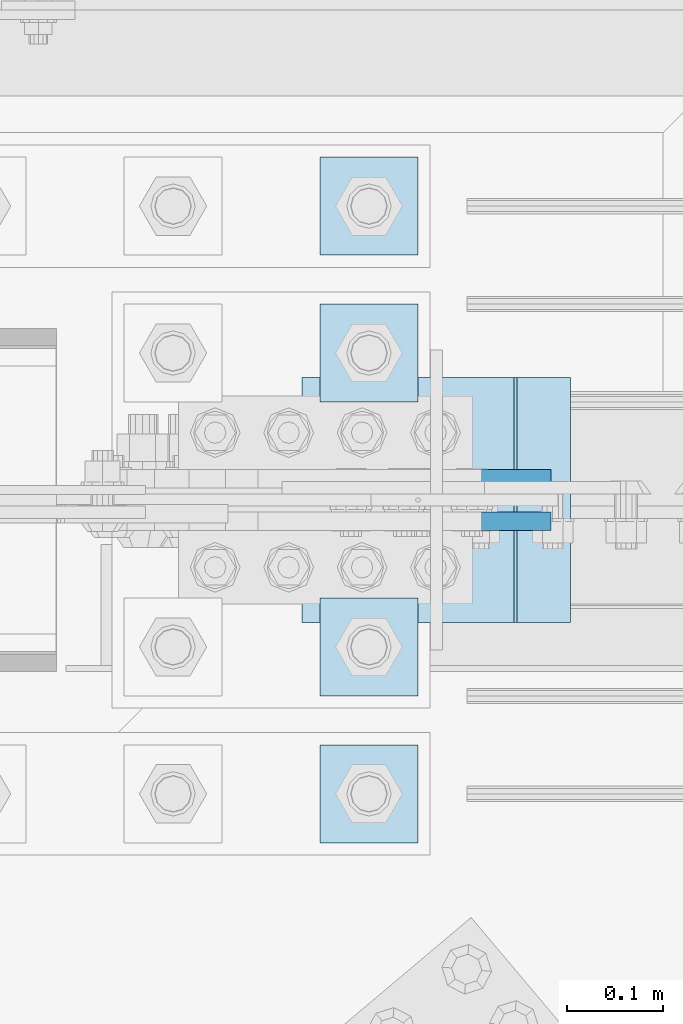
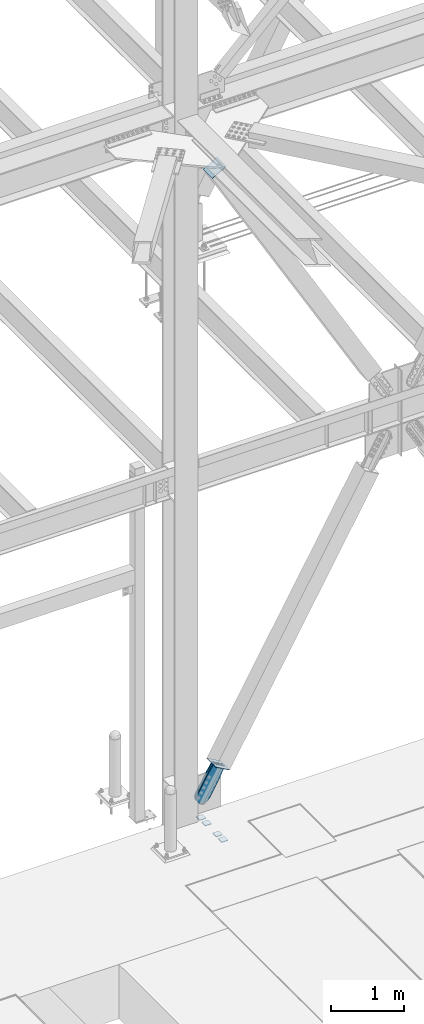
# One storey, part 3465 of 3843: 8 plates, 5 elements without a shape of their own.
"""IFC2X3 building model written with IfcOpenShell, lengths in millimetres."""

from ifc_helpers import new_model, si_unit, frame, origin_with_axes, place, context, subcontext, project, spatial, faceted_brep, material, type_object, element, aggregate, save


model = new_model("IFC2X3")

# Units and contexts
model_context = context("Model", 3, precision=1e-05, world=origin_with_axes())
body_context = subcontext(model_context, "Body", "Model", "MODEL_VIEW")
ifc_project = project(units=[si_unit("LENGTHUNIT", "METRE", prefix="MILLI"), si_unit("AREAUNIT", "SQUARE_METRE"), si_unit("VOLUMEUNIT", "CUBIC_METRE"), si_unit("MASSUNIT", "GRAM", prefix="KILO"), si_unit("TIMEUNIT", "SECOND"), si_unit("PLANEANGLEUNIT", "RADIAN"), si_unit("SOLIDANGLEUNIT", "STERADIAN"), si_unit("THERMODYNAMICTEMPERATUREUNIT", "DEGREE_CELSIUS"), si_unit("LUMINOUSINTENSITYUNIT", "LUMEN")], contexts=[model_context])

# Site, building, storey
site_placement = place(None, origin_with_axes())
site = spatial("IfcSite", under=ifc_project, at=site_placement, CompositionType="ELEMENT")
building_placement = place(site_placement, origin_with_axes())
building = spatial("IfcBuilding", under=site, at=building_placement, Name="Undefined", CompositionType="ELEMENT")
storey_placement = place(building_placement, origin_with_axes())
storey = spatial("IfcBuildingStorey", under=building, at=storey_placement, Name="Undefined", CompositionType="ELEMENT", Elevation=0.0)

# Assembly, plates
assembly_1_placement = place(storey_placement, origin_with_axes())
assembly_1 = element("IfcElementAssembly", 1, at=assembly_1_placement, inside=storey, Name="TEMPLATE", AssemblyPlace="NOTDEFINED", PredefinedType="RIGID_FRAME")
ifc_material_1 = material(Name="STEEL/A572-50")
plate_type_1 = type_object("IfcPlateType", PredefinedType="NOTDEFINED")
plate_1_placement = place(assembly_1_placement, frame((49555.4, 91960.7, 30143.45), z_axis=(-1.0, 0.0, 0.0), x_axis=(0.0, -1.0, 0.0)))
plate_1 = element("IfcPlate", 2, at=plate_1_placement, type_object=plate_type_1, material=ifc_material_1, Name="Washer Plate", context=body_context, shape_type="Brep", body=[
    faceted_brep([(0.0, -6.3499999046162, 0.0), (-1.67347025126219e-10, -6.35000000000582, 101.600000000151), (-1.67347025126219e-10, 6.35000000000582, 101.600000000151), (7.27595761418343e-12, 6.3499999046162, 0.0), (101.599998474121, -6.34999999999854, 101.599998474121), (101.599998474121, 6.34999999999854, 101.599998474121), (101.6, -6.34999999999854, 0.0), (101.6, 6.34999999999854, 0.0)], [[[0, 1, 2, 3]], [[1, 4, 5, 2]], [[4, 6, 7, 5]], [[6, 0, 3, 7]], [[5, 7, 3, 2]], [[6, 4, 1, 0]]]),
])
plate_2_placement = place(assembly_1_placement, frame((49555.4, 92113.1, 30143.45), z_axis=(-1.0, 0.0, 0.0), x_axis=(0.0, -1.0, 0.0)))
plate_2 = element("IfcPlate", 3, at=plate_2_placement, type_object=plate_type_1, material=ifc_material_1, Name="Washer Plate", context=body_context, shape_type="Brep", body=[
    faceted_brep([(0.0, -6.3499999046162, 0.0), (-1.67347025126219e-10, -6.35000000000582, 101.600000000151), (-1.67347025126219e-10, 6.35000000000582, 101.600000000151), (7.27595761418343e-12, 6.3499999046162, 0.0), (101.599998474121, -6.34999999999854, 101.599998474121), (101.599998474121, 6.34999999999854, 101.599998474121), (101.6, -6.34999999999854, 0.0), (101.6, 6.34999999999854, 0.0)], [[[0, 1, 2, 3]], [[1, 4, 5, 2]], [[4, 6, 7, 5]], [[6, 0, 3, 7]], [[5, 7, 3, 2]], [[6, 4, 1, 0]]]),
])
plate_3_placement = place(assembly_1_placement, frame((49555.4, 92417.9, 30143.45), z_axis=(-1.0, 0.0, 0.0), x_axis=(0.0, -1.0, 0.0)))
plate_3 = element("IfcPlate", 4, at=plate_3_placement, type_object=plate_type_1, material=ifc_material_1, Name="Washer Plate", context=body_context, shape_type="Brep", body=[
    faceted_brep([(0.0, -6.3499999046162, 0.0), (-1.67347025126219e-10, -6.35000000000582, 101.600000000151), (-1.67347025126219e-10, 6.35000000000582, 101.600000000151), (7.27595761418343e-12, 6.3499999046162, 0.0), (101.599998474121, -6.34999999999854, 101.599998474121), (101.599998474121, 6.34999999999854, 101.599998474121), (101.6, -6.34999999999854, 0.0), (101.6, 6.34999999999854, 0.0)], [[[0, 1, 2, 3]], [[1, 4, 5, 2]], [[4, 6, 7, 5]], [[6, 0, 3, 7]], [[5, 7, 3, 2]], [[6, 4, 1, 0]]]),
])
plate_4_placement = place(assembly_1_placement, frame((49555.4, 92570.3, 30143.45), z_axis=(-1.0, 0.0, 0.0), x_axis=(0.0, -1.0, 0.0)))
plate_4 = element("IfcPlate", 5, at=plate_4_placement, type_object=plate_type_1, material=ifc_material_1, Name="Washer Plate", context=body_context, shape_type="Brep", body=[
    faceted_brep([(0.0, -6.3499999046162, 0.0), (-1.67347025126219e-10, -6.35000000000582, 101.600000000151), (-1.67347025126219e-10, 6.35000000000582, 101.600000000151), (7.27595761418343e-12, 6.3499999046162, 0.0), (101.599998474121, -6.34999999999854, 101.599998474121), (101.599998474121, 6.34999999999854, 101.599998474121), (101.6, -6.34999999999854, 0.0), (101.6, 6.34999999999854, 0.0)], [[[0, 1, 2, 3]], [[1, 4, 5, 2]], [[4, 6, 7, 5]], [[6, 0, 3, 7]], [[5, 7, 3, 2]], [[6, 4, 1, 0]]]),
])
aggregate(assembly_1, [plate_1, plate_2, plate_3, plate_4])

# Assembly, plate
assembly_2_placement = place(storey_placement, origin_with_axes())
assembly_2 = element("IfcElementAssembly", 6, at=assembly_2_placement, inside=storey, Name="Plate", AssemblyPlace="NOTDEFINED", PredefinedType="RIGID_FRAME")
ifc_material_2 = material(Name="STEEL/A36")
plate_type_2 = type_object("IfcPlateType", PredefinedType="NOTDEFINED")
plate_5_placement = place(assembly_2_placement, frame((49711.8716965723, 92087.7, 31132.5717676098), z_axis=(-0.868187207007649, 0.0, 0.496236812004368), x_axis=(0.0, 1.0, 0.0)))
plate_5 = element("IfcPlate", 7, at=plate_5_placement, type_object=plate_type_2, material=ifc_material_2, Name="Plate", context=body_context, shape_type="Brep", body=[
    faceted_brep([(0.0, -3.17499999999927, 0.0), (0.0, -3.17499999965185, 254.000000005151), (0.0, 3.17500000035216, 254.000000005166), (0.0, 3.17499999999927, 0.0), (254.0, -3.17499999965185, 254.000000005151), (254.0, 3.17500000035216, 254.000000005166), (254.0, -3.17500000000291, 0.0), (254.0, 3.17499999999927, 1.45519152283669e-11)], [[[0, 1, 2, 3]], [[1, 4, 5, 2]], [[4, 6, 7, 5]], [[6, 0, 3, 7]], [[5, 7, 3, 2]], [[6, 4, 1, 0]]]),
])
aggregate(assembly_2, [plate_5])

assembly_3_placement = place(storey_placement, origin_with_axes())
assembly_3 = element("IfcElementAssembly", 8, at=assembly_3_placement, inside=storey, Name="Plate", AssemblyPlace="NOTDEFINED", PredefinedType="RIGID_FRAME")
plate_6_placement = place(assembly_3_placement, frame((49436.770562099, 92341.7, 41182.6523233866), z_axis=(0.865635480884955, 0.0, 0.500674758933454), x_axis=(0.0, -1.0, 0.0)))
plate_6 = element("IfcPlate", 9, at=plate_6_placement, type_object=plate_type_2, material=ifc_material_2, Name="Plate", context=body_context, shape_type="Brep", body=[
    faceted_brep([(0.0, -3.17499999999927, 0.0), (0.0, -3.17499999965185, 254.000000005151), (0.0, 3.17500000035216, 254.000000005166), (0.0, 3.17499999999927, 0.0), (254.0, -3.17499999965185, 254.000000005151), (254.0, 3.17500000035216, 254.000000005166), (254.0, -3.17500000000291, 0.0), (254.0, 3.17499999999927, 1.45519152283669e-11)], [[[0, 1, 2, 3]], [[1, 4, 5, 2]], [[4, 6, 7, 5]], [[6, 0, 3, 7]], [[5, 7, 3, 2]], [[6, 4, 1, 0]]]),
])
aggregate(assembly_3, [plate_6])

assembly_4_placement = place(storey_placement, origin_with_axes())
assembly_4 = element("IfcElementAssembly", 10, at=assembly_4_placement, inside=storey, AssemblyPlace="NOTDEFINED", PredefinedType="RIGID_FRAME")
plate_type_3 = type_object("IfcPlateType", PredefinedType="NOTDEFINED")
plate_7_placement = place(assembly_4_placement, frame((49658.8110220957, 92236.925, 31086.1021355656), z_axis=(-0.868187207007649, 0.0, 0.496236812004368), x_axis=(0.496236812004375, 0.0, 0.868187207007645)))
plate_7 = element("IfcPlate", 11, at=plate_7_placement, type_object=plate_type_3, material=ifc_material_2, context=body_context, shape_type="Brep", body=[
    faceted_brep([(0.0, -9.52500000000146, 0.0), (-101.600000000224, -9.52499999999418, -8.71915661533421), (-101.600000000224, 9.52499999999418, -8.71915661533421), (0.0, 9.52500000000146, 0.0), (-441.169864343115, -9.52499999999418, -8.71915661469393), (-441.169864343115, 9.52499999999418, -8.71915661469393), (-484.303071297451, -9.52499999999418, -0.139428306654736), (-484.303071297451, 9.52499999999418, -0.139428306654736), (-520.86963849645, -9.52499999999418, 24.2935707578508), (-520.86963849645, 9.52499999999418, 24.2935707578508), (-545.302637560817, -9.52499999999418, 60.8601379569373), (-545.302637560817, 9.52499999999418, 60.8601379569373), (-553.882365868703, -9.52499999999418, 103.993341860187), (-553.882365868703, 9.52499999999418, 103.993341860187), (-545.302637560671, -9.52499999999418, 147.126548814522), (-545.302637560671, 9.52499999999418, 147.126548814522), (-520.869638496166, -9.52499999999418, 183.693116013514), (-520.869638496166, 9.52499999999418, 183.693116013514), (-484.303071297072, -9.52499999999418, 208.126115077888), (-484.303071297072, 9.52499999999418, 208.126115077888), (-441.16986586828, -9.52499999999418, 216.705843385775), (-441.16986586828, 9.52499999999418, 216.705843385775), (-101.599999999817, -9.52499999999418, 216.705843385134), (-101.599999999817, 9.52499999999418, 216.705843385134), (-1.45519152283669e-11, -9.52499999999418, 207.986686767843), (-1.45519152283669e-11, 9.52499999999418, 207.986686767843), (69.8499999996129, -9.52499999999418, 207.986686767857), (69.8499999996129, 9.52499999999418, 207.986686767857), (69.8499999979995, -9.52499999999418, -4.00177668780088e-10), (69.8499999979995, 9.52499999999418, -4.00177668780088e-10)], [[[0, 1, 2, 3]], [[1, 4, 5, 2]], [[4, 6, 7, 5]], [[6, 8, 9, 7]], [[8, 10, 11, 9]], [[10, 12, 13, 11]], [[12, 14, 15, 13]], [[14, 16, 17, 15]], [[16, 18, 19, 17]], [[18, 20, 21, 19]], [[20, 22, 23, 21]], [[22, 24, 25, 23]], [[24, 26, 27, 25]], [[26, 28, 29, 27]], [[28, 0, 3, 29]], [[5, 7, 9, 11, 13, 15, 17, 19, 21, 23, 25, 27, 29, 3, 2]], [[28, 26, 24, 22, 20, 18, 16, 14, 12, 10, 8, 6, 4, 1, 0]]]),
])
aggregate(assembly_4, [plate_7])

assembly_5_placement = place(storey_placement, origin_with_axes())
assembly_5 = element("IfcElementAssembly", 12, at=assembly_5_placement, inside=storey, AssemblyPlace="NOTDEFINED", PredefinedType="RIGID_FRAME")
plate_8_placement = place(assembly_5_placement, frame((49658.8110220957, 92192.475, 31086.1021355656), z_axis=(-0.868187207007649, 0.0, 0.496236812004368), x_axis=(0.496236812004375, 0.0, 0.868187207007645)))
plate_8 = element("IfcPlate", 13, at=plate_8_placement, type_object=plate_type_3, material=ifc_material_2, context=body_context, shape_type="Brep", body=[
    faceted_brep([(0.0, -9.52500000000146, 0.0), (-101.600000000224, -9.52499999999418, -8.71915661533421), (-101.600000000224, 9.52499999999418, -8.71915661533421), (0.0, 9.52500000000146, 0.0), (-441.169864343115, -9.52499999999418, -8.71915661469393), (-441.169864343115, 9.52499999999418, -8.71915661469393), (-484.303071297451, -9.52499999999418, -0.139428306654736), (-484.303071297451, 9.52499999999418, -0.139428306654736), (-520.86963849645, -9.52499999999418, 24.2935707578508), (-520.86963849645, 9.52499999999418, 24.2935707578508), (-545.302637560817, -9.52499999999418, 60.8601379569373), (-545.302637560817, 9.52499999999418, 60.8601379569373), (-553.882365868703, -9.52499999999418, 103.993341860187), (-553.882365868703, 9.52499999999418, 103.993341860187), (-545.302637560671, -9.52499999999418, 147.126548814522), (-545.302637560671, 9.52499999999418, 147.126548814522), (-520.869638496166, -9.52499999999418, 183.693116013514), (-520.869638496166, 9.52499999999418, 183.693116013514), (-484.303071297072, -9.52499999999418, 208.126115077888), (-484.303071297072, 9.52499999999418, 208.126115077888), (-441.16986586828, -9.52499999999418, 216.705843385775), (-441.16986586828, 9.52499999999418, 216.705843385775), (-101.599999999817, -9.52499999999418, 216.705843385134), (-101.599999999817, 9.52499999999418, 216.705843385134), (-1.45519152283669e-11, -9.52499999999418, 207.986686767843), (-1.45519152283669e-11, 9.52499999999418, 207.986686767843), (69.8499999996129, -9.52499999999418, 207.986686767857), (69.8499999996129, 9.52499999999418, 207.986686767857), (69.8499999979995, -9.52499999999418, -4.00177668780088e-10), (69.8499999979995, 9.52499999999418, -4.00177668780088e-10)], [[[0, 1, 2, 3]], [[1, 4, 5, 2]], [[4, 6, 7, 5]], [[6, 8, 9, 7]], [[8, 10, 11, 9]], [[10, 12, 13, 11]], [[12, 14, 15, 13]], [[14, 16, 17, 15]], [[16, 18, 19, 17]], [[18, 20, 21, 19]], [[20, 22, 23, 21]], [[22, 24, 25, 23]], [[24, 26, 27, 25]], [[26, 28, 29, 27]], [[28, 0, 3, 29]], [[5, 7, 9, 11, 13, 15, 17, 19, 21, 23, 25, 27, 29, 3, 2]], [[28, 26, 24, 22, 20, 18, 16, 14, 12, 10, 8, 6, 4, 1, 0]]]),
])
aggregate(assembly_5, [plate_8])

save(model, "model.ifc")
